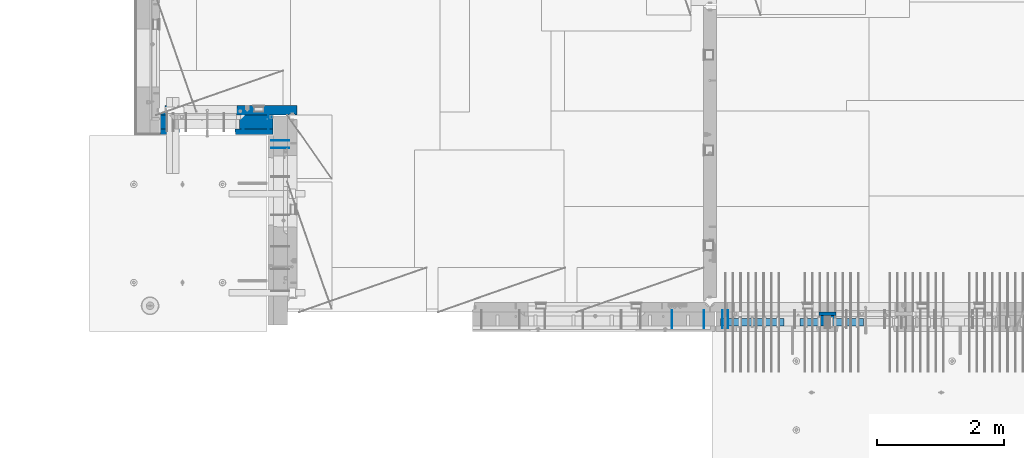
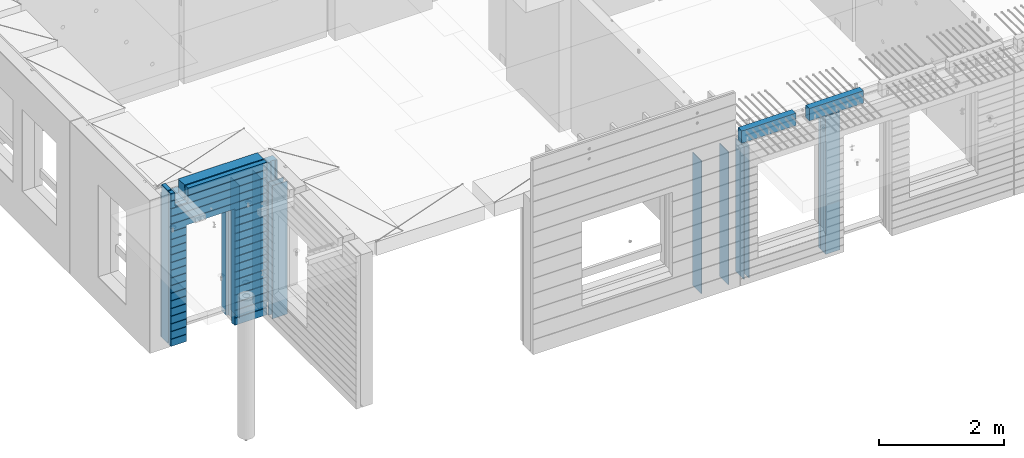
# One storey, part 194 of 309: 15 walls, 7 elements without a shape of their own.
"""IFC2X3 building model written with IfcOpenShell, lengths in millimetres."""

from ifc_helpers import new_model, si_unit, frame, origin_with_axes, place, context, subcontext, project, spatial, faceted_brep, material, type_object, element, aggregate, save


model = new_model("IFC2X3")

# Units and contexts
model_context = context("Model", 3, precision=1e-05, world=origin_with_axes())
body_context = subcontext(model_context, "Body", "Model", "MODEL_VIEW")
ifc_project = project(units=[si_unit("LENGTHUNIT", "METRE", prefix="MILLI"), si_unit("AREAUNIT", "SQUARE_METRE"), si_unit("VOLUMEUNIT", "CUBIC_METRE"), si_unit("MASSUNIT", "GRAM", prefix="KILO"), si_unit("TIMEUNIT", "SECOND"), si_unit("PLANEANGLEUNIT", "RADIAN"), si_unit("SOLIDANGLEUNIT", "STERADIAN"), si_unit("THERMODYNAMICTEMPERATUREUNIT", "DEGREE_CELSIUS"), si_unit("LUMINOUSINTENSITYUNIT", "LUMEN")], contexts=[model_context])

# Site, building, storey
site_placement = place(None, origin_with_axes())
site = spatial("IfcSite", under=ifc_project, at=site_placement, CompositionType="ELEMENT")
building_placement = place(site_placement, origin_with_axes())
building = spatial("IfcBuilding", under=site, at=building_placement, CompositionType="ELEMENT")
storey_placement = place(building_placement, origin_with_axes())
storey = spatial("IfcBuildingStorey", under=building, at=storey_placement, Name="7", CompositionType="ELEMENT", Elevation=0.0)

# Assembly, wall
assembly_1_placement = place(storey_placement, origin_with_axes())
assembly_1 = element("IfcElementAssembly", 1, at=assembly_1_placement, inside=storey, AssemblyPlace="NOTDEFINED", PredefinedType="REINFORCEMENT_UNIT")
ifc_material_1 = material(Name="Undefined")
wall_type_1 = type_object("IfcWallType", PredefinedType="NOTDEFINED")
wall_1_placement = place(assembly_1_placement, frame((10040.0, 10550.0, 101115.0), z_axis=(0.0, 0.0, 1.0), x_axis=(-1.0, 3.00000001838171e-08, 0.0)))
wall_1 = element("IfcWall", 2, at=wall_1_placement, type_object=wall_type_1, material=ifc_material_1, Name="(PD)", context=body_context, shape_type="Brep", body=[
    faceted_brep([(0.0, 5.0, -1300.0), (0.0, 5.0, 1300.0), (280.0, 5.0, 1300.0), (280.0, 5.0, -1300.0), (0.0, -5.0, 1300.0), (280.0, -5.0, 1300.0), (0.0, -5.0, -1300.0), (280.0, -5.0, -1300.0)], [[[0, 1, 2, 3]], [[1, 4, 5, 2]], [[4, 6, 7, 5]], [[6, 0, 3, 7]], [[5, 7, 3, 2]], [[6, 4, 1, 0]]]),
])

# Assembly, walls
assembly_2_placement = place(storey_placement, origin_with_axes())
assembly_2 = element("IfcElementAssembly", 3, at=assembly_2_placement, inside=storey, AssemblyPlace="NOTDEFINED", PredefinedType="REINFORCEMENT_UNIT")
wall_2_placement = place(assembly_2_placement, frame((16565.0, 7880.0, 101115.0), z_axis=(0.0, 0.0, 1.0), x_axis=(0.0, -1.0, 0.0)))
wall_2 = element("IfcWall", 4, at=wall_2_placement, type_object=wall_type_1, material=ifc_material_1, Name="(PD)", context=body_context, shape_type="Brep", body=[
    faceted_brep([(0.0, 5.0, -1300.0), (0.0, 5.0, 1300.0), (280.0, 5.0, 1300.0), (280.0, 5.0, -1300.0), (0.0, -5.0, 1300.0), (280.0, -5.0, 1300.0), (0.0, -5.0, -1300.0), (280.0, -5.0, -1300.0)], [[[0, 1, 2, 3]], [[1, 4, 5, 2]], [[4, 6, 7, 5]], [[6, 0, 3, 7]], [[5, 7, 3, 2]], [[6, 4, 1, 0]]]),
])
wall_3_placement = place(assembly_2_placement, frame((16065.0, 7880.0, 101115.0), z_axis=(0.0, 0.0, 1.0), x_axis=(0.0, -1.0, 0.0)))
wall_3 = element("IfcWall", 5, at=wall_3_placement, type_object=wall_type_1, material=ifc_material_1, Name="(PD)", context=body_context, shape_type="Brep", body=[
    faceted_brep([(0.0, 5.0, -1300.0), (0.0, 5.0, 1300.0), (280.0, 5.0, 1300.0), (280.0, 5.0, -1300.0), (0.0, -5.0, 1300.0), (280.0, -5.0, 1300.0), (0.0, -5.0, -1300.0), (280.0, -5.0, -1300.0)], [[[0, 1, 2, 3]], [[1, 4, 5, 2]], [[4, 6, 7, 5]], [[6, 0, 3, 7]], [[5, 7, 3, 2]], [[6, 4, 1, 0]]]),
])
aggregate(assembly_2, [wall_2, wall_3])

assembly_3_placement = place(storey_placement, origin_with_axes())
assembly_3 = element("IfcElementAssembly", 6, at=assembly_3_placement, inside=storey, AssemblyPlace="NOTDEFINED", PredefinedType="REINFORCEMENT_UNIT")
wall_4_placement = place(assembly_3_placement, frame((16855.0, 7880.0, 101115.0), z_axis=(0.0, 0.0, 1.0), x_axis=(0.0, -1.0, 0.0)))
wall_4 = element("IfcWall", 7, at=wall_4_placement, type_object=wall_type_1, material=ifc_material_1, Name="(PD)", context=body_context, shape_type="Brep", body=[
    faceted_brep([(0.0, 5.0, -1300.0), (0.0, 5.0, 1300.0), (280.0, 5.0, 1300.0), (280.0, 5.0, -1300.0), (0.0, -5.0, 1300.0), (280.0, -5.0, 1300.0), (0.0, -5.0, -1300.0), (280.0, -5.0, -1300.0)], [[[0, 1, 2, 3]], [[1, 4, 5, 2]], [[4, 6, 7, 5]], [[6, 0, 3, 7]], [[5, 7, 3, 2]], [[6, 4, 1, 0]]]),
])
wall_5_placement = place(assembly_3_placement, frame((16945.0, 7880.0, 101115.0), z_axis=(0.0, 0.0, 1.0), x_axis=(0.0, -1.0, 0.0)))
wall_5 = element("IfcWall", 8, at=wall_5_placement, type_object=wall_type_1, material=ifc_material_1, Name="(PD)", context=body_context, shape_type="Brep", body=[
    faceted_brep([(0.0, 5.0, -1300.0), (0.0, 5.0, 1300.0), (280.0, 5.0, 1300.0), (280.0, 5.0, -1300.0), (0.0, -5.0, 1300.0), (280.0, -5.0, 1300.0), (0.0, -5.0, -1300.0), (280.0, -5.0, -1300.0)], [[[0, 1, 2, 3]], [[1, 4, 5, 2]], [[4, 6, 7, 5]], [[6, 0, 3, 7]], [[5, 7, 3, 2]], [[6, 4, 1, 0]]]),
])

assembly_4_placement = place(storey_placement, origin_with_axes())
assembly_4 = element("IfcElementAssembly", 9, at=assembly_4_placement, inside=storey, AssemblyPlace="NOTDEFINED", PredefinedType="REINFORCEMENT_UNIT")
wall_6_placement = place(assembly_4_placement, frame((9315.0, 10980.0, 101115.0), z_axis=(0.0, 0.0, 1.0), x_axis=(0.0, -1.0, 0.0)))
wall_6 = element("IfcWall", 10, at=wall_6_placement, type_object=wall_type_1, material=ifc_material_1, Name="(PD)", context=body_context, shape_type="Brep", body=[
    faceted_brep([(0.0, 5.0, -1300.0), (0.0, 5.0, 1300.0), (280.0, 5.0, 1300.0), (280.0, 5.0, -1300.0), (0.0, -5.0, 1300.0), (280.0, -5.0, 1300.0), (0.0, -5.0, -1300.0), (280.0, -5.0, -1300.0)], [[[0, 1, 2, 3]], [[1, 4, 5, 2]], [[4, 6, 7, 5]], [[6, 0, 3, 7]], [[5, 7, 3, 2]], [[6, 4, 1, 0]]]),
])
wall_7_placement = place(assembly_4_placement, frame((9715.0, 10980.0, 101115.0), z_axis=(0.0, 0.0, 1.0), x_axis=(0.0, -1.0, 0.0)))
wall_7 = element("IfcWall", 11, at=wall_7_placement, type_object=wall_type_1, material=ifc_material_1, Name="(PD)", context=body_context, shape_type="Brep", body=[
    faceted_brep([(0.0, 5.0, -1300.0), (0.0, 5.0, 1300.0), (280.0, 5.0, 1300.0), (280.0, 5.0, -1300.0), (0.0, -5.0, 1300.0), (280.0, -5.0, 1300.0), (0.0, -5.0, -1300.0), (280.0, -5.0, -1300.0)], [[[0, 1, 2, 3]], [[1, 4, 5, 2]], [[4, 6, 7, 5]], [[6, 0, 3, 7]], [[5, 7, 3, 2]], [[6, 4, 1, 0]]]),
])

# Wall
wall_8_placement = place(assembly_1_placement, frame((10040.0, 10430.0, 101115.0), z_axis=(0.0, 0.0, 1.0), x_axis=(-1.0, 3.00000001838171e-08, 0.0)))
wall_8 = element("IfcWall", 12, at=wall_8_placement, type_object=wall_type_1, material=ifc_material_1, Name="(PD)", context=body_context, shape_type="Brep", body=[
    faceted_brep([(0.0, 5.0, -1300.0), (0.0, 5.0, 1300.0), (280.0, 5.0, 1300.0), (280.0, 5.0, -1300.0), (0.0, -5.0, 1300.0), (280.0, -5.0, 1300.0), (0.0, -5.0, -1300.0), (280.0, -5.0, -1300.0)], [[[0, 1, 2, 3]], [[1, 4, 5, 2]], [[4, 6, 7, 5]], [[6, 0, 3, 7]], [[5, 7, 3, 2]], [[6, 4, 1, 0]]]),
])

aggregate(assembly_1, [wall_1, wall_8])

# Assemblies, walls
assembly_5_placement = place(storey_placement, origin_with_axes())
assembly_5 = element("IfcElementAssembly", 13, at=assembly_5_placement, inside=storey, AssemblyPlace="NOTDEFINED", PredefinedType="REINFORCEMENT_UNIT")
assembly_6_placement = place(assembly_5_placement, origin_with_axes())
assembly_6 = element("IfcElementAssembly", 14, at=assembly_6_placement, Name="Steel Assembly", AssemblyPlace="NOTDEFINED", PredefinedType="NOTDEFINED")
ifc_material_2 = material()
wall_type_2 = type_object("IfcWallType", PredefinedType="NOTDEFINED")
wall_9_placement = place(assembly_6_placement, frame((18074.9998568133, 7690.00021946163, 102590.0), z_axis=(0.0, 0.0, 1.0), x_axis=(1.0, 0.0, 0.0)))
wall_9 = element("IfcWall", 15, at=wall_9_placement, type_object=wall_type_2, material=ifc_material_2, context=body_context, shape_type="Brep", body=[
    faceted_brep([(0.0, 60.0, -120.0), (0.0, 60.0, 120.0), (1000.0, 60.0, 120.0), (1000.0, 60.0, -120.0), (0.0, -60.0, 120.0), (1000.0, -60.0, 120.0), (0.0, -60.0, -120.0), (1000.0, -60.0, -120.0)], [[[0, 1, 2, 3]], [[1, 4, 5, 2]], [[4, 6, 7, 5]], [[6, 0, 3, 7]], [[5, 7, 3, 2]], [[6, 4, 1, 0]]]),
])
aggregate(assembly_6, [wall_9])
assembly_7_placement = place(assembly_5_placement, origin_with_axes())
assembly_7 = element("IfcElementAssembly", 16, at=assembly_7_placement, Name="Steel Assembly", AssemblyPlace="NOTDEFINED", PredefinedType="NOTDEFINED")
aggregate(assembly_5, [assembly_6, assembly_7])
wall_10_placement = place(assembly_7_placement, frame((16824.9998568133, 7690.00021946163, 102590.0), z_axis=(0.0, 0.0, 1.0), x_axis=(1.0, 0.0, 0.0)))
wall_10 = element("IfcWall", 17, at=wall_10_placement, type_object=wall_type_2, material=ifc_material_2, context=body_context, shape_type="Brep", body=[
    faceted_brep([(0.0, 60.0, -120.0), (0.0, 60.0, 120.0), (1000.0, 60.0, 120.0), (1000.0, 60.0, -120.0), (0.0, -60.0, 120.0), (1000.0, -60.0, 120.0), (0.0, -60.0, -120.0), (1000.0, -60.0, -120.0)], [[[0, 1, 2, 3]], [[1, 4, 5, 2]], [[4, 6, 7, 5]], [[6, 0, 3, 7]], [[5, 7, 3, 2]], [[6, 4, 1, 0]]]),
])
aggregate(assembly_7, [wall_10])

# Wall
ifc_material_3 = material(Name="COS5gt")
wall_type_3 = type_object("IfcWallType", PredefinedType="NOTDEFINED")
wall_11_placement = place(assembly_4_placement, frame((9785.0, 10840.0, 101247.5), z_axis=(0.0, 0.0, 1.0), x_axis=(-1.0, 3.00000001838171e-08, 0.0)))
wall_11 = element("IfcWall", 18, at=wall_11_placement, type_object=wall_type_3, material=ifc_material_3, context=body_context, shape_type="Brep", body=[
    faceted_brep([(1700.0, -110.0, 1492.5), (1700.0, 90.0, 1492.5), (1700.0, 90.0, 1442.5), (1700.0, 110.0, 1442.5), (1700.0, 109.999999999998, 1222.5), (1700.0, -110.0, 1222.5), (1460.0, 109.999999999998, 1222.5), (1460.0, -110.0, 1222.5), (1460.0, -110.0, 1492.5), (1460.0, 110.0, 1442.5), (1460.0, 90.0, 1442.5), (1460.0, 90.0, 1492.5), (0.0, -110.0, -1492.5), (0.0, 90.0, -1492.5), (530.001442432404, 90.0, -1492.5), (530.001442432404, -110.0, -1492.5), (0.0, 90.0, -1442.5), (0.0, 110.0, -1442.5), (530.001442432404, 110.0, -1442.5), (530.001442432404, 90.0, -1442.5), (1770.0002741176, 90.0, -1442.5), (1770.0002741176, 90.0, -1492.5), (1540.0014424324, 90.0, -1492.5), (1540.0014424324, 90.0, -1442.5), (1770.0002741176, 110.0, -1442.5), (1540.0014424324, 110.0, -1442.5), (1770.0002741176, 110.0, 1442.5), (1770.0002741176, 90.0, 1442.5), (1770.0002741176, 90.0, 1492.5), (1770.0002741176, -110.0, 1492.5), (1770.0002741176, -110.0, -1492.5), (1540.0014424324, -110.0, -1492.5), (1540.0014424324, -110.0, 847.5), (1540.0014424324, 110.0, 847.5), (530.001442432404, -110.0, 847.5), (530.001442432404, 110.0, 847.5), (0.0, -110.0, 1492.5), (0.0, 90.0, 1492.5), (0.0, 90.0, 1442.5), (0.0, 110.0, 1442.5)], [[[0, 1, 2, 3, 4, 5]], [[5, 4, 6, 7]], [[8, 7, 6, 9, 10, 11]], [[12, 13, 14, 15]], [[16, 17, 18, 19]], [[20, 21, 22, 23]], [[24, 20, 23, 25]], [[26, 27, 28, 29, 30, 21, 20, 24]], [[21, 30, 31, 22]], [[32, 33, 25, 23, 22, 31]], [[34, 35, 33, 32]], [[15, 14, 19, 18, 35, 34]], [[13, 16, 19, 14]], [[13, 12, 36, 37, 38, 39, 17, 16]], [[37, 36, 8, 11]], [[38, 37, 11, 10]], [[39, 38, 10, 9]], [[4, 3, 26, 24, 25, 33, 35, 18, 17, 39, 9, 6]], [[27, 26, 3, 2]], [[28, 27, 2, 1]], [[29, 28, 1, 0]], [[36, 12, 15, 34, 32, 31, 30, 29, 0, 5, 7, 8]]]),
])

ifc_material_4 = material(Name="CONCRETE/C30/37")
wall_type_4 = type_object("IfcWallType", PredefinedType="NOTDEFINED")
wall_12_placement = place(assembly_4_placement, frame((9785.0, 10687.5, 101247.5), z_axis=(0.0, 0.0, 1.0), x_axis=(-1.0, 3.00000001838171e-08, 0.0)))
wall_12 = element("IfcWall", 19, at=wall_12_placement, type_object=wall_type_4, material=ifc_material_4, context=body_context, shape_type="Brep", body=[
    faceted_brep([(1700.0, -42.5, 1492.5), (1700.0, 42.5, 1492.5), (1700.0, 42.5, 1356.99999988925), (1700.0, 32.4999991126915, 1355.00000040043), (1700.0, 32.4999992506928, 1344.9999999992), (1700.0, 42.5, 1342.99999994476), (1700.0, 42.5, 1222.5), (1700.0, -42.5, 1222.5), (1460.0, 42.5, 1222.5), (1460.0, -42.5, 1222.5), (1460.0, -42.5, 1492.5), (1460.0, 42.5, 1342.99999994476), (1460.0, 32.4999992506928, 1344.9999999992), (1460.0, 32.4999991126915, 1355.00000040043), (1460.0, 42.5, 1356.99999988925), (1460.0, 42.5, 1492.5), (1479.99938360887, 42.5, 606.999999889245), (1769.99994039504, 42.5, 606.999999889245), (1769.99994039505, 32.4999991126915, 605.000000400425), (1478.8227168378, 32.4999991126915, 605.000000400425), (1769.99994039505, 32.4999992506928, 594.9999999992), (1478.82271685404, 32.4999992506928, 594.9999999992), (1769.99994039504, 42.5, 592.999999944761), (1479.99938360887, 42.5, 592.999999944761), (1769.99994039504, 42.5, 456.999999889245), (1479.99938360887, 42.5, 456.999999889245), (1769.99994039505, 32.4999991126915, 455.000000400425), (1478.8227168378, 32.4999991126915, 455.000000400425), (1769.99994039505, 32.4999992506928, 444.9999999992), (1478.82271685404, 32.4999992506928, 444.9999999992), (1769.99994039504, 42.5, 442.999999944761), (1479.99938360887, 42.5, 442.999999944761), (1769.99994039504, 42.5, 306.999999889245), (1479.99938360887, 42.5, 306.999999889245), (1769.99994039505, 32.4999991126915, 305.000000400425), (1478.8227168378, 32.4999991126915, 305.000000400425), (1769.99994039505, 32.4999992506928, 294.9999999992), (1478.82271685404, 32.4999992506928, 294.9999999992), (1769.99994039504, 42.5, 292.999999944761), (1479.99938360887, 42.5, 292.999999944761), (1769.99994039504, 42.5, 156.999999889245), (1479.99938360887, 42.5, 156.999999889245), (1769.99994039504, 32.4999991126915, 155.000000400425), (1478.8227168378, 32.4999991126915, 155.000000400425), (1769.99994039504, 32.4999992506928, 144.9999999992), (1478.82271685404, 32.4999992506928, 144.9999999992), (1769.99994039504, 42.5, 142.999999944761), (1479.99938360887, 42.5, 142.999999944761), (1769.99994039504, 42.5, 6.99999988924537), (1479.99938360887, 42.5, 6.99999988924537), (1769.99994039504, 32.4999991126915, 5.00000040042505), (1478.8227168378, 32.4999991126915, 5.00000040042505), (1769.99994039504, 32.4999992506928, -5.00000000080036), (1478.82271685404, 32.4999992506928, -5.00000000080036), (1769.99994039504, 42.5, -7.00000005523907), (1479.99938360887, 42.5, -7.00000005523907), (1769.99994039504, 42.5, -143.000000110755), (1479.99938360887, 42.5, -143.000000110755), (1769.99994039504, 32.4999991126915, -144.999999599575), (1478.8227168378, 32.4999991126915, -144.999999599575), (1769.99994039504, 32.4999992506928, -155.0000000008), (1478.82271685404, 32.4999992506928, -155.0000000008), (1769.99994039504, 42.5, -157.000000055239), (1479.99938360887, 42.5, -157.000000055239), (1769.99994039504, 42.5, -293.000000110755), (1479.99938360887, 42.5, -293.000000110755), (1769.99994039504, 32.4999991126915, -294.999999599575), (1478.8227168378, 32.4999991126915, -294.999999599575), (1769.99994039504, 32.4999992506928, -305.0000000008), (1478.82271685404, 32.4999992506928, -305.0000000008), (1769.99994039504, 42.5, -307.000000055239), (1479.99938360887, 42.5, -307.000000055239), (1769.99994039504, 42.5, -443.000000110755), (1479.99938360887, 42.5, -443.000000110755), (1769.99994039504, 32.4999991126915, -444.999999599575), (1478.8227168378, 32.4999991126915, -444.999999599575), (1769.99994039504, 32.4999992506928, -455.0000000008), (1478.82271685404, 32.4999992506928, -455.0000000008), (1769.99994039504, 42.5, -457.000000055239), (1479.99938360887, 42.5, -457.000000055239), (1769.99994039504, 42.5, -593.000000110755), (1479.99938360887, 42.5, -593.000000110755), (1769.99994039504, 32.4999991126915, -594.999999599575), (1478.8227168378, 32.4999991126915, -594.999999599575), (1769.99994039504, 32.4999992506928, -605.0000000008), (1478.82271685404, 32.4999992506928, -605.0000000008), (1769.99994039504, 42.5, -607.000000055239), (1479.99938360887, 42.5, -607.000000055239), (1769.99994039504, 42.5, -743.000000110755), (1479.99938360887, 42.5, -743.000000110755), (1769.99994039504, 32.4999991126915, -744.999999599575), (1478.8227168378, 32.4999991126915, -744.999999599575), (1769.99994039504, 32.4999992506928, -755.0000000008), (1478.82271685404, 32.4999992506928, -755.0000000008), (1769.99994039504, 42.5, -757.000000055239), (1479.99938360887, 42.5, -757.000000055239), (1769.99994039504, 42.5, -893.000000110755), (1479.99938360887, 42.5, -893.000000110755), (1769.99994039504, 32.4999991126915, -894.999999599575), (1478.8227168378, 32.4999991126915, -894.999999599575), (1769.99994039504, 32.4999992506928, -905.0000000008), (1478.82271685404, 32.4999992506928, -905.0000000008), (1769.99994039504, 42.5, -907.000000055239), (1479.99938360887, 42.5, -907.000000055239), (1769.99994039504, 42.5, -1043.00000011075), (1479.99938360887, 42.5, -1043.00000011075), (1769.99994039504, 32.4999991126915, -1044.99999959957), (1478.8227168378, 32.4999991126915, -1044.99999959957), (1769.99994039504, 32.4999992506928, -1055.0000000008), (1478.82271685404, 32.4999992506928, -1055.0000000008), (1769.99994039504, 42.5, -1057.00000005524), (1479.99938360887, 42.5, -1057.00000005524), (1769.99994039504, 42.5, -1193.00000011075), (1479.99938360887, 42.5, -1193.00000011075), (1769.99994039504, 32.4999991126915, -1194.99999959957), (1478.8227168378, 32.4999991126915, -1194.99999959957), (1769.99994039504, 32.4999992506928, -1205.0000000008), (1478.82271685404, 32.4999992506928, -1205.0000000008), (1769.99994039504, 42.5, -1207.00000005524), (1479.99938360887, 42.5, -1207.00000005524), (1769.99994039504, 42.5, -1343.00000011075), (1479.99938360887, 42.5, -1343.00000011075), (1769.99994039504, 32.4999991126915, -1344.99999959957), (1478.8227168378, 32.4999991126915, -1344.99999959957), (1769.99994039504, 32.4999992506928, -1355.0000000008), (1478.82271685404, 32.4999992506928, -1355.0000000008), (1769.99994039504, 42.5, -1357.00000005524), (1479.99938360887, 42.5, -1357.00000005524), (1769.99994039504, 42.5, -1492.5), (1479.99938360887, 42.5, -1492.5), (1769.99994039504, -42.5, -1492.5), (1469.99771694221, -42.5, -1492.5), (600.001442432404, 42.5, 782.5), (1470.0014424324, 42.5, 782.5), (1479.99938360887, 42.5, 782.5), (1469.99771694221, -42.5, 787.502857142856), (600.001050275541, -42.5, 787.502857142856), (589.999383608874, 42.5, 782.5), (1479.99938360887, 42.5, 742.999999944761), (1469.99771694221, -42.5, 782.5), (1479.99938360887, 42.5, 756.999999889245), (1478.8227168378, 32.4999991126915, 755.000000400425), (1478.82271685404, 32.4999992506928, 744.9999999992), (1769.99994039504, 42.5, 742.999999944761), (1769.99994039505, 32.4999992506928, 744.9999999992), (1769.99994039505, 32.4999991126915, 755.000000400425), (1769.99994039504, 42.5, 756.999999889245), (0.0, 32.4999991127006, 905.00000040044), (1769.99994039505, 32.4999991126915, 905.000000400425), (1769.99994039505, 32.4999992506928, 894.9999999992), (0.0, 32.4999992507037, 894.999999999258), (0.0, 42.5, 906.999999889245), (1769.99994039504, 42.5, 906.999999889245), (0.0, 42.5, 1042.99999994476), (1769.99994039504, 42.5, 1042.99999994476), (0.0, 32.4999992507037, 1044.99999999926), (1769.99994039505, 32.4999992506928, 1044.9999999992), (0.0, 32.4999991127006, 1055.00000040044), (1769.99994039505, 32.4999991126915, 1055.00000040043), (0.0, 42.5, 1056.99999988925), (1769.99994039504, 42.5, 1056.99999988925), (0.0, 42.5, 1192.99999994476), (1769.99994039504, 42.5, 1192.99999994476), (0.0, 32.4999992507037, 1194.99999999926), (1769.99994039505, 32.4999992506928, 1194.9999999992), (0.0, 32.4999991127006, 1205.00000040044), (1769.99994039505, 32.4999991126915, 1205.00000040043), (0.0, 42.5, 1206.99999988925), (1769.99994039504, 42.5, 1206.99999988925), (1769.99994039504, 42.5, 1492.5), (1769.99994039504, -42.5, 1492.5), (1769.99994039504, 42.5, 892.999999944761), (1769.99994039504, 42.5, 1342.99999994476), (1769.99994039505, 32.4999992506928, 1344.9999999992), (1769.99994039505, 32.4999991126915, 1355.00000040043), (1769.99994039504, 42.5, 1356.99999988925), (0.0, 42.5, 892.999999944761), (589.999383608874, 42.5, 756.999999889245), (0.0, 42.5, 756.999999889245), (589.999383608874, 42.5, -1492.5), (0.0, 42.5, -1492.5), (0.0, 42.5, -1357.00000005524), (589.999383608874, 42.5, -1357.00000005524), (0.0, 32.4999992507037, -1355.00000000074), (591.176050363707, 32.4999992506928, -1355.0000000008), (0.0, 32.4999991127006, -1344.99999959956), (591.176050379949, 32.4999991126915, -1344.99999959957), (0.0, 42.5, -1343.00000011075), (589.999383608874, 42.5, -1343.00000011075), (0.0, 42.5, -1207.00000005524), (589.999383608874, 42.5, -1207.00000005524), (0.0, 32.4999992507037, -1205.00000000074), (591.176050363709, 32.4999992506928, -1205.0000000008), (0.0, 32.4999991127006, -1194.99999959956), (591.176050379947, 32.4999991126915, -1194.99999959957), (0.0, 42.5, -1193.00000011075), (589.999383608874, 42.5, -1193.00000011075), (0.0, 42.5, -1057.00000005524), (589.999383608874, 42.5, -1057.00000005524), (0.0, 32.4999992507037, -1055.00000000074), (591.176050363711, 32.4999992506928, -1055.0000000008), (0.0, 32.4999991127006, -1044.99999959956), (591.176050379949, 32.4999991126915, -1044.99999959957), (0.0, 42.5, -1043.00000011075), (589.999383608874, 42.5, -1043.00000011075), (0.0, 42.5, -907.000000055239), (589.999383608874, 42.5, -907.000000055239), (0.0, 32.4999992507037, -905.000000000742), (591.176050363711, 32.4999992506928, -905.0000000008), (0.0, 32.4999991127006, -894.99999959956), (591.176050379949, 32.4999991126915, -894.999999599575), (0.0, 42.5, -893.000000110755), (589.999383608874, 42.5, -893.000000110755), (0.0, 42.5, -757.000000055239), (589.999383608874, 42.5, -757.000000055239), (0.0, 32.4999992507037, -755.000000000742), (591.176050363711, 32.4999992506928, -755.0000000008), (0.0, 32.4999991127006, -744.99999959956), (591.176050379949, 32.4999991126915, -744.999999599575), (0.0, 42.5, -743.000000110755), (589.999383608874, 42.5, -743.000000110755), (0.0, 42.5, -607.000000055239), (589.999383608874, 42.5, -607.000000055239), (3.63797880709171e-12, 32.4999992507037, -605.000000000742), (591.176050363711, 32.4999992506928, -605.0000000008), (3.63797880709171e-12, 32.4999991127006, -594.99999959956), (591.176050379949, 32.4999991126915, -594.999999599575), (0.0, 42.5, -593.000000110755), (589.999383608874, 42.5, -593.000000110755), (0.0, 42.5, -457.000000055239), (589.999383608874, 42.5, -457.000000055239), (0.0, 32.4999992507037, -455.000000000742), (591.176050363711, 32.4999992506928, -455.0000000008), (0.0, 32.4999991127006, -444.99999959956), (591.176050379949, 32.4999991126915, -444.999999599575), (0.0, 42.5, -443.000000110755), (589.999383608874, 42.5, -443.000000110755), (0.0, 42.5, -307.000000055239), (589.999383608874, 42.5, -307.000000055239), (0.0, 32.4999992507037, -305.000000000742), (591.176050363707, 32.4999992506928, -305.0000000008), (0.0, 32.4999991127006, -294.99999959956), (591.176050379945, 32.4999991126915, -294.999999599575), (0.0, 42.5, -293.000000110755), (589.999383608874, 42.5, -293.000000110755), (0.0, 42.5, -157.000000055239), (589.999383608874, 42.5, -157.000000055239), (3.63797880709171e-12, 32.4999992507037, -155.000000000742), (591.176050363707, 32.4999992506928, -155.0000000008), (3.63797880709171e-12, 32.4999991127006, -144.99999959956), (591.176050379945, 32.4999991126915, -144.999999599575), (0.0, 42.5, -143.000000110755), (589.999383608874, 42.5, -143.000000110755), (0.0, 42.5, -7.00000005523907), (589.999383608874, 42.5, -7.00000005523907), (0.0, 32.4999992507037, -5.00000000074215), (591.176050363705, 32.4999992506928, -5.00000000080036), (0.0, 32.4999991127006, 5.0000004004396), (591.176050379945, 32.4999991126915, 5.00000040042505), (0.0, 42.5, 6.99999988924537), (589.999383608874, 42.5, 6.99999988924537), (0.0, 42.5, 142.999999944761), (589.999383608874, 42.5, 142.999999944761), (-3.63797880709171e-12, 32.4999992507037, 144.999999999258), (591.176050363705, 32.4999992506928, 144.9999999992), (-3.63797880709171e-12, 32.4999991127006, 155.00000040044), (591.176050379943, 32.4999991126915, 155.000000400425), (0.0, 42.5, 156.999999889245), (589.999383608874, 42.5, 156.999999889245), (0.0, 42.5, 292.999999944761), (589.999383608874, 42.5, 292.999999944761), (-3.63797880709171e-12, 32.4999992507037, 294.999999999258), (591.176050363705, 32.4999992506928, 294.9999999992), (-3.63797880709171e-12, 32.4999991127006, 305.00000040044), (591.176050379943, 32.4999991126915, 305.000000400425), (0.0, 42.5, 306.999999889245), (589.999383608874, 42.5, 306.999999889245), (0.0, 42.5, 442.999999944761), (589.999383608874, 42.5, 442.999999944761), (0.0, 32.4999992507037, 444.999999999258), (591.176050363705, 32.4999992506928, 444.9999999992), (0.0, 32.4999991127006, 455.00000040044), (591.176050379941, 32.4999991126915, 455.000000400425), (0.0, 42.5, 456.999999889245), (589.999383608874, 42.5, 456.999999889245), (0.0, 42.5, 592.999999944761), (589.999383608874, 42.5, 592.999999944761), (3.63797880709171e-12, 32.4999992507037, 594.999999999258), (591.176050363702, 32.4999992506928, 594.9999999992), (3.63797880709171e-12, 32.4999991127006, 605.00000040044), (591.176050379941, 32.4999991126915, 605.000000400425), (0.0, 42.5, 606.999999889245), (589.999383608874, 42.5, 606.999999889245), (0.0, 42.5, 742.999999944761), (589.999383608874, 42.5, 742.999999944761), (0.0, 32.4999992507037, 744.999999999258), (591.176050363705, 32.4999992506928, 744.9999999992), (0.0, 32.4999991127006, 755.00000040044), (591.176050379943, 32.4999991126915, 755.000000400425), (600.001050275541, -42.5, 782.5), (600.001050275539, -42.5, -1492.5), (0.0, -42.5, -1492.5), (-3.63797880709171e-12, 32.4999992507037, 1344.99999999926), (0.0, 42.5, 1342.99999994476), (0.0, -42.5, 1492.5), (0.0, 42.5, 1492.5), (0.0, 42.5, 1356.99999988925), (-3.63797880709171e-12, 32.4999991127006, 1355.00000040044)], [[[0, 1, 2, 3, 4, 5, 6, 7]], [[7, 6, 8, 9]], [[10, 9, 8, 11, 12, 13, 14, 15]], [[16, 17, 18, 19]], [[19, 18, 20, 21]], [[21, 20, 22, 23]], [[24, 25, 23, 22]], [[25, 24, 26, 27]], [[27, 26, 28, 29]], [[29, 28, 30, 31]], [[32, 33, 31, 30]], [[33, 32, 34, 35]], [[35, 34, 36, 37]], [[37, 36, 38, 39]], [[40, 41, 39, 38]], [[41, 40, 42, 43]], [[43, 42, 44, 45]], [[45, 44, 46, 47]], [[48, 49, 47, 46]], [[49, 48, 50, 51]], [[51, 50, 52, 53]], [[53, 52, 54, 55]], [[56, 57, 55, 54]], [[57, 56, 58, 59]], [[59, 58, 60, 61]], [[61, 60, 62, 63]], [[64, 65, 63, 62]], [[65, 64, 66, 67]], [[67, 66, 68, 69]], [[69, 68, 70, 71]], [[72, 73, 71, 70]], [[73, 72, 74, 75]], [[75, 74, 76, 77]], [[77, 76, 78, 79]], [[80, 81, 79, 78]], [[81, 80, 82, 83]], [[83, 82, 84, 85]], [[85, 84, 86, 87]], [[88, 89, 87, 86]], [[89, 88, 90, 91]], [[91, 90, 92, 93]], [[93, 92, 94, 95]], [[96, 97, 95, 94]], [[97, 96, 98, 99]], [[99, 98, 100, 101]], [[101, 100, 102, 103]], [[104, 105, 103, 102]], [[105, 104, 106, 107]], [[107, 106, 108, 109]], [[109, 108, 110, 111]], [[112, 113, 111, 110]], [[113, 112, 114, 115]], [[115, 114, 116, 117]], [[117, 116, 118, 119]], [[120, 121, 119, 118]], [[121, 120, 122, 123]], [[123, 122, 124, 125]], [[125, 124, 126, 127]], [[128, 129, 127, 126]], [[128, 130, 131, 129]], [[132, 133, 134, 135, 136, 137]], [[138, 16, 19, 21, 23, 25, 27, 29, 31, 33, 35, 37, 39, 41, 43, 45, 47, 49, 51, 53, 55, 57, 59, 61, 63, 65, 67, 69, 71, 73, 75, 77, 79, 81, 83, 85, 87, 89, 91, 93, 95, 97, 99, 101, 103, 105, 107, 109, 111, 113, 115, 117, 119, 121, 123, 125, 127, 129, 131, 139, 135, 134, 140, 141, 142]], [[17, 16, 138, 143]], [[142, 144, 143, 138]], [[141, 145, 144, 142]], [[140, 146, 145, 141]], [[147, 148, 149, 150]], [[151, 152, 148, 147]], [[152, 151, 153, 154]], [[155, 156, 154, 153]], [[157, 158, 156, 155]], [[159, 160, 158, 157]], [[160, 159, 161, 162]], [[163, 164, 162, 161]], [[165, 166, 164, 163]], [[167, 168, 166, 165]], [[169, 170, 130, 128, 126, 124, 122, 120, 118, 116, 114, 112, 110, 108, 106, 104, 102, 100, 98, 96, 94, 92, 90, 88, 86, 84, 82, 80, 78, 76, 74, 72, 70, 68, 66, 64, 62, 60, 58, 56, 54, 52, 50, 48, 46, 44, 42, 40, 38, 36, 34, 32, 30, 28, 26, 24, 22, 20, 18, 17, 143, 144, 145, 146, 171, 149, 148, 152, 154, 156, 158, 160, 162, 164, 166, 168, 172, 173, 174, 175]], [[150, 149, 171, 176]], [[146, 140, 134, 133, 132, 137, 177, 178, 176, 171]], [[179, 180, 181, 182]], [[183, 184, 182, 181]], [[185, 186, 184, 183]], [[187, 188, 186, 185]], [[188, 187, 189, 190]], [[191, 192, 190, 189]], [[193, 194, 192, 191]], [[195, 196, 194, 193]], [[196, 195, 197, 198]], [[199, 200, 198, 197]], [[201, 202, 200, 199]], [[203, 204, 202, 201]], [[204, 203, 205, 206]], [[207, 208, 206, 205]], [[209, 210, 208, 207]], [[211, 212, 210, 209]], [[212, 211, 213, 214]], [[215, 216, 214, 213]], [[217, 218, 216, 215]], [[219, 220, 218, 217]], [[220, 219, 221, 222]], [[223, 224, 222, 221]], [[225, 226, 224, 223]], [[227, 228, 226, 225]], [[228, 227, 229, 230]], [[231, 232, 230, 229]], [[233, 234, 232, 231]], [[235, 236, 234, 233]], [[236, 235, 237, 238]], [[239, 240, 238, 237]], [[241, 242, 240, 239]], [[243, 244, 242, 241]], [[244, 243, 245, 246]], [[247, 248, 246, 245]], [[249, 250, 248, 247]], [[251, 252, 250, 249]], [[252, 251, 253, 254]], [[255, 256, 254, 253]], [[257, 258, 256, 255]], [[259, 260, 258, 257]], [[260, 259, 261, 262]], [[263, 264, 262, 261]], [[265, 266, 264, 263]], [[267, 268, 266, 265]], [[268, 267, 269, 270]], [[271, 272, 270, 269]], [[273, 274, 272, 271]], [[275, 276, 274, 273]], [[276, 275, 277, 278]], [[279, 280, 278, 277]], [[281, 282, 280, 279]], [[283, 284, 282, 281]], [[284, 283, 285, 286]], [[287, 288, 286, 285]], [[289, 290, 288, 287]], [[291, 292, 290, 289]], [[292, 291, 293, 294]], [[295, 296, 294, 293]], [[297, 298, 296, 295]], [[178, 177, 298, 297]], [[137, 136, 299, 300, 179, 182, 184, 186, 188, 190, 192, 194, 196, 198, 200, 202, 204, 206, 208, 210, 212, 214, 216, 218, 220, 222, 224, 226, 228, 230, 232, 234, 236, 238, 240, 242, 244, 246, 248, 250, 252, 254, 256, 258, 260, 262, 264, 266, 268, 270, 272, 274, 276, 278, 280, 282, 284, 286, 288, 290, 292, 294, 296, 298, 177]], [[301, 180, 179, 300]], [[302, 303, 167, 165, 163, 161, 159, 157, 155, 153, 151, 147, 150, 176, 178, 297, 295, 293, 291, 289, 287, 285, 283, 281, 279, 277, 275, 273, 271, 269, 267, 265, 263, 261, 259, 257, 255, 253, 251, 249, 247, 245, 243, 241, 239, 237, 235, 233, 231, 229, 227, 225, 223, 221, 219, 217, 215, 213, 211, 209, 207, 205, 203, 201, 199, 197, 195, 193, 191, 189, 187, 185, 183, 181, 180, 301, 304, 305, 306, 307]], [[305, 304, 10, 15]], [[306, 305, 15, 14]], [[307, 306, 14, 13]], [[302, 307, 13, 12]], [[303, 302, 12, 11]], [[6, 5, 172, 168, 167, 303, 11, 8]], [[173, 172, 5, 4]], [[174, 173, 4, 3]], [[175, 174, 3, 2]], [[169, 175, 2, 1]], [[170, 169, 1, 0]], [[304, 301, 300, 299, 136, 135, 139, 131, 130, 170, 0, 7, 9, 10]]]),
])

ifc_material_5 = material(Name="CONCRETE/C25/30")
wall_type_5 = type_object("IfcWallType", PredefinedType="NOTDEFINED")
wall_13_placement = place(assembly_4_placement, frame((10160.0, 11025.0, 101112.5), z_axis=(0.0, 0.0, 1.0), x_axis=(-1.0, 3.00000001838171e-08, 0.0)))
wall_13 = element("IfcWall", 20, at=wall_13_placement, type_object=wall_type_5, material=ifc_material_5, context=body_context, shape_type="Brep", body=[
    faceted_brep([(47.9999996848892, 54.9999994175323, 1357.5), (47.9999996848892, 54.9999994175323, -1357.5), (34.999999998452, 55.0000022791301, -1357.5), (34.999999998452, 55.0000022791301, 1357.5), (24.999999998452, 75.0000022791301, 1357.5), (24.999999998452, 75.0, -1357.5), (124.999999998452, 75.0, 1357.5), (124.999999998452, 75.0, -1357.5), (114.999999998452, 55.0000022791301, -1357.5), (114.999999998452, 55.0000022791301, 1357.5), (101.99999958942, 54.999999390373, 1357.5), (101.99999958942, 54.999999390373, -1357.5), (945.001442432404, -75.0, -1357.5), (949.055496486459, 75.0, -1357.5), (949.055496486457, 75.0, 948.445945945947), (945.001442432404, -75.0, 952.5), (0.0, -75.0, -1357.5), (0.0, 75.0, -1357.5), (2145.0, 75.0, 1357.5), (2145.0, 75.0, -1357.5), (1870.94738837835, 75.0, -1357.5), (1870.94738837835, 75.0, 948.445945945947), (2145.0, 45.0, 1357.5), (2145.0, 45.0, -1357.5), (2074.9999995581, 32.0, 1357.5), (2074.9999995581, 32.0, -1357.5), (2074.9999995581, -75.0, 1357.5), (2074.9999995581, -75.0, -1357.5), (1875.0014424324, -75.0, -1357.5), (1875.0014424324, -75.0, 952.5), (0.0, -75.0, 1357.5), (0.0, 75.0, 1357.5)], [[[0, 1, 2, 3]], [[4, 3, 2, 5]], [[6, 7, 8, 9]], [[10, 9, 8, 11]], [[10, 11, 1, 0]], [[12, 13, 14, 15]], [[1, 11, 8, 7, 13, 12, 16, 17, 5, 2]], [[18, 19, 20, 21, 14, 13, 7, 6]], [[19, 18, 22, 23]], [[24, 25, 23, 22]], [[26, 27, 25, 24]], [[19, 23, 25, 27, 28, 20]], [[20, 28, 29, 21]], [[15, 14, 21, 29]], [[28, 27, 26, 30, 16, 12, 15, 29]], [[16, 30, 31, 17]], [[17, 31, 4, 5]], [[31, 30, 26, 24, 22, 18, 6, 9, 10, 0, 3, 4]]]),
])

aggregate(assembly_4, [wall_6, wall_7, wall_12, wall_11, wall_13])

ifc_material_6 = material(Name="CONCRETE/C35/45")
wall_type_6 = type_object("IfcWallType", PredefinedType="NOTDEFINED")
wall_14_placement = place(assembly_3_placement, frame((18645.0200381475, 7825.0, 101112.5), z_axis=(0.0, 0.0, 1.0), x_axis=(-1.0, 3.00000001838171e-08, 0.0)))
wall_14 = element("IfcWall", 21, at=wall_14_placement, type_object=wall_type_6, material=ifc_material_6, context=body_context, shape_type="Brep", body=[
    faceted_brep([(0.0, 25.0, -1357.5), (0.0, 25.0, 1357.5), (270.001908754726, 25.0, 1357.5), (270.001908754726, 25.0, -1357.5), (0.0, -25.0, 1357.5), (270.001908754726, -25.0, 1357.5), (0.0, -25.0, -1357.5), (270.001908754726, -25.0, -1357.5)], [[[0, 1, 2, 3]], [[1, 4, 5, 2]], [[4, 6, 7, 5]], [[6, 0, 3, 7]], [[5, 7, 3, 2]], [[6, 4, 1, 0]]]),
])

ifc_material_7 = material(Name="SPU")
wall_type_7 = type_object("IfcWallType", PredefinedType="NOTDEFINED")
wall_15_placement = place(assembly_3_placement, frame((18645.0100381475, 7715.0, 101102.5), z_axis=(0.0, 0.0, 1.0), x_axis=(-1.0, 3.00000001838171e-08, 0.0)))
wall_15 = element("IfcWall", 22, at=wall_15_placement, type_object=wall_type_7, material=ifc_material_7, context=body_context, shape_type="Brep", body=[
    faceted_brep([(0.0, 85.0, -1347.5), (0.0, 85.0, 1347.5), (270.001908754726, 85.0, 1347.5), (270.001908754726, 85.0, -1347.5), (0.0, -85.0, 1347.5), (270.001908754726, -85.0, 1347.5), (0.0, -85.0, -1347.5), (270.001908754726, -85.0, -1347.5)], [[[0, 1, 2, 3]], [[1, 4, 5, 2]], [[4, 6, 7, 5]], [[6, 0, 3, 7]], [[5, 7, 3, 2]], [[6, 4, 1, 0]]]),
])

aggregate(assembly_3, [wall_14, wall_15, wall_4, wall_5])

save(model, "model.ifc")
